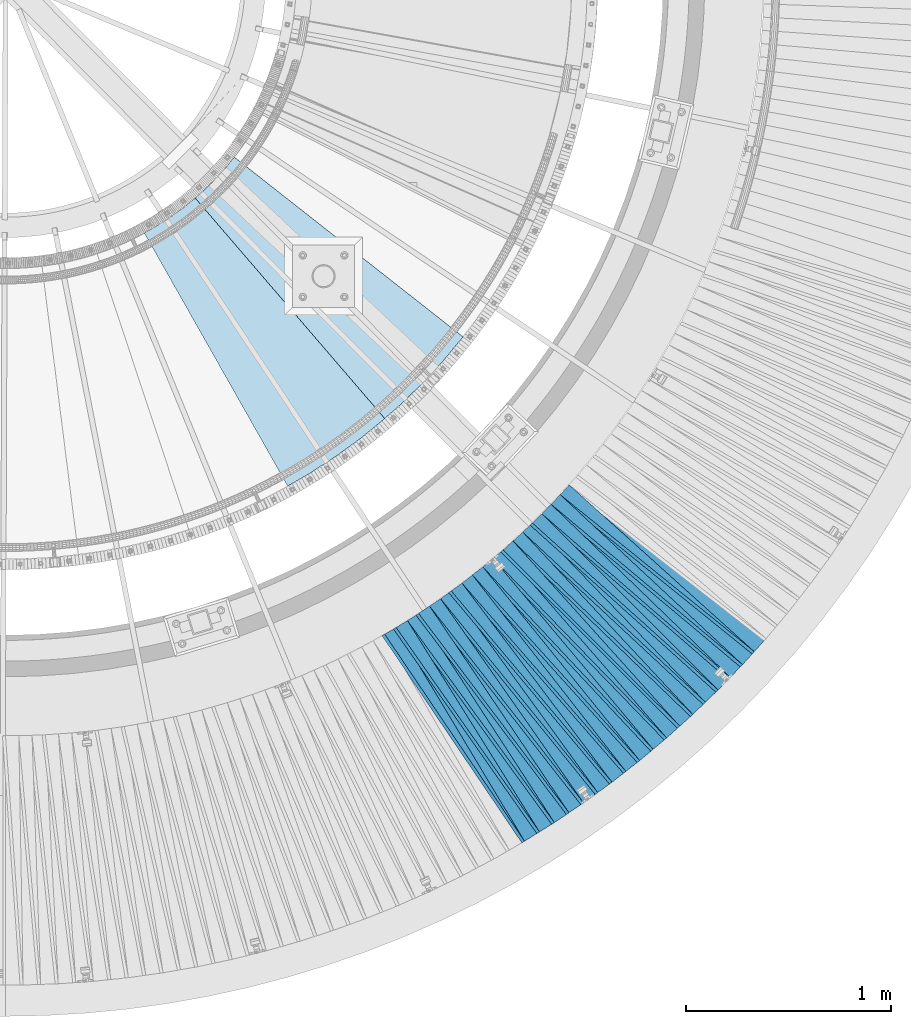
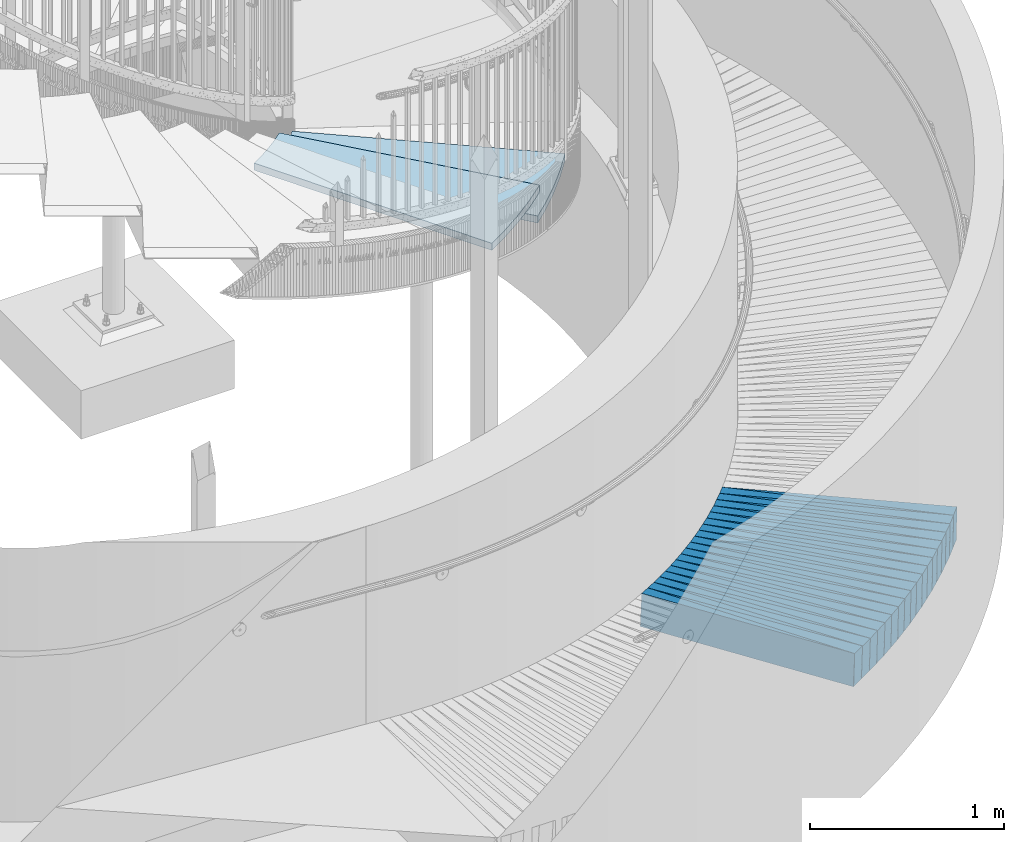
# One storey, part 832 of 975: 38 plates.
"""IFC2X3 building model written with IfcOpenShell, lengths in millimetres."""

from ifc_helpers import new_model, si_unit, frame, origin_with_axes, place, context, subcontext, project, spatial, faceted_brep, material, type_object, element, save


model = new_model("IFC2X3")

# Units and contexts
model_context = context("Model", 3, precision=1e-05, world=origin_with_axes())
body_context = subcontext(model_context, "Body", "Model", "MODEL_VIEW")
ifc_project = project(units=[si_unit("LENGTHUNIT", "METRE", prefix="MILLI"), si_unit("AREAUNIT", "SQUARE_METRE"), si_unit("VOLUMEUNIT", "CUBIC_METRE"), si_unit("MASSUNIT", "GRAM", prefix="KILO"), si_unit("TIMEUNIT", "SECOND"), si_unit("PLANEANGLEUNIT", "RADIAN"), si_unit("SOLIDANGLEUNIT", "STERADIAN"), si_unit("THERMODYNAMICTEMPERATUREUNIT", "DEGREE_CELSIUS"), si_unit("LUMINOUSINTENSITYUNIT", "LUMEN")], contexts=[model_context])

# Site, building, storey
site_placement = place(None, origin_with_axes())
site = spatial("IfcSite", under=ifc_project, at=site_placement, CompositionType="ELEMENT")
building_placement = place(site_placement, origin_with_axes())
building = spatial("IfcBuilding", under=site, at=building_placement, Name="Undefined", CompositionType="ELEMENT")
storey_placement = place(building_placement, origin_with_axes())
storey = spatial("IfcBuildingStorey", under=building, at=storey_placement, Name="Undefined", CompositionType="ELEMENT", Elevation=0.0)

# Plates
ifc_material_1 = material(Name="STEEL/A36")
plate_type_1 = type_object("IfcPlateType", PredefinedType="NOTDEFINED")
plate_1_placement = place(storey_placement, frame((37340.4592339061, -777.500208121454, 627.062023763603), z_axis=(-0.817299788050078, -0.573410252178987, 0.056760366007701), x_axis=(-0.57414473231509, 0.818743986449328, 0.00401385200220284)))
element("IfcPlate", 1, at=plate_1_placement, inside=storey, type_object=plate_type_1, material=ifc_material_1, Name="SLAB", context=body_context, shape_type="Brep", body=[
    faceted_brep([(-6.82121026329696e-12, -100.000000000011, -1.09139364212751e-10), (4.54009294510615, -99.9999999999918, 86.0067901611546), (4.54009294474236, 99.9999999999677, 86.0067901606271), (5.91171556152403e-12, 100.000000000011, 1.09139364212751e-10), (1220.77233886818, -99.9999999999491, -4.98403096571565e-10), (1220.77233886782, 100.00000000001, -1.02227204479277e-09)], [[[0, 1, 2, 3]], [[1, 4, 5, 2]], [[4, 0, 3, 5]], [[5, 3, 2]], [[4, 1, 0]]]),
])
plate_2_placement = place(storey_placement, frame((37413.3106687025, -732.147513354668, 622.068841281269), z_axis=(-0.807184923926217, -0.587448092964748, 0.0579416659952725), x_axis=(-0.588239751870621, 0.80867623682214, 0.00409124899910022)))
element("IfcPlate", 2, at=plate_2_placement, inside=storey, type_object=plate_type_1, material=ifc_material_1, Name="SLAB", context=body_context, shape_type="Brep", body=[
    faceted_brep([(-6.82121026329696e-12, -100.000000000011, -1.09139364212751e-10), (6.10836553567424, -100.000000000002, 85.8623809813835), (6.10836553595072, 100.00000000002, 85.8623809817509), (5.91171556152403e-12, 100.000000000011, 1.09139364212751e-10), (1222.12072754039, -99.9999999998786, 2.29920260608196e-09), (1222.12072754066, 100.000000000143, 2.66663846559823e-09)], [[[0, 1, 2, 3]], [[1, 4, 5, 2]], [[4, 0, 3, 5]], [[5, 3, 2]], [[4, 1, 0]]]),
])
plate_3_placement = place(storey_placement, frame((37484.7655241083, -684.067685249771, 617.161944634053), z_axis=(-0.796803579112582, -0.601567867133516, 0.0567464320095237), x_axis=(-0.602351830177366, 0.798220621235036, 0.00401404000118194)))
element("IfcPlate", 3, at=plate_3_placement, inside=storey, type_object=plate_type_1, material=ifc_material_1, Name="SLAB", context=body_context, shape_type="Brep", body=[
    faceted_brep([(-6.82121026329696e-12, -100.000000000011, -1.09139364212751e-10), (4.57294225681835, -100.000000000011, 86.0255661009323), (4.57294225706937, 100.000000000018, 86.0255661012743), (5.91171556152403e-12, 100.000000000011, 1.09139364212751e-10), (1220.71508789306, -99.9999999997754, 3.68527253158391e-09), (1220.71508789331, 100.000000000254, 4.02724253945053e-09)], [[[0, 1, 2, 3]], [[1, 4, 5, 2]], [[4, 0, 3, 5]], [[5, 3, 2]], [[4, 1, 0]]]),
])
plate_4_placement = place(storey_placement, frame((37556.0252663577, -636.114886571845, 612.168553459172), z_axis=(-0.78614168604072, -0.615328986134024, 0.0578920399738097), x_axis=(-0.6161707098645, 0.787602003826803, 0.0040914389991003)))
element("IfcPlate", 4, at=plate_4_placement, inside=storey, type_object=plate_type_1, material=ifc_material_1, Name="SLAB", context=body_context, shape_type="Brep", body=[
    faceted_brep([(-6.82121026329696e-12, -100.000000000011, -1.09139364212751e-10), (6.06977224327784, -100.000000000015, 85.9386901852631), (6.06977224361617, 100.000000000008, 85.9386901857069), (5.91171556152403e-12, 100.000000000011, 1.09139364212751e-10), (1222.06396484426, -99.9999999999895, -1.23691279441118e-09), (1222.0639648446, 100.000000000034, -7.96717358753085e-10)], [[[0, 1, 2, 3]], [[1, 4, 5, 2]], [[4, 0, 3, 5]], [[5, 3, 2]], [[4, 1, 0]]]),
])
plate_5_placement = place(storey_placement, frame((37625.6841162659, -585.597140831808, 607.168442500744), z_axis=(-0.775236426847244, -0.629014504488151, 0.0578725810089996), x_axis=(-0.629880829859821, 0.776680991827151, 0.00409598699908845)))
element("IfcPlate", 5, at=plate_5_placement, inside=storey, type_object=plate_type_1, material=ifc_material_1, Name="SLAB", context=body_context, shape_type="Brep", body=[
    faceted_brep([(-6.82121026329696e-12, -100.000000000011, -1.09139364212751e-10), (4.56012725799519, -100.000000000017, 86.0739517208203), (4.56012725838445, 100.00000000001, 86.0739517213005), (5.91171556152403e-12, 100.000000000011, 1.09139364212751e-10), (1220.70715332002, -100.000000000052, -1.87719706445932e-09), (1220.70715332041, 99.999999999975, -1.38970790430903e-09)], [[[0, 1, 2, 3]], [[1, 4, 5, 2]], [[4, 0, 3, 5]], [[5, 3, 2]], [[4, 1, 0]]]),
])
plate_6_placement = place(storey_placement, frame((37695.4344143507, -535.11381683741, 602.261958150688), z_axis=(-0.764205394462062, -0.642471518171804, 0.0567491269809581), x_axis=(-0.643328914129797, 0.765579409154459, 0.00400955400080898)))
element("IfcPlate", 6, at=plate_6_placement, inside=storey, type_object=plate_type_1, material=ifc_material_1, Name="SLAB", context=body_context, shape_type="Brep", body=[
    faceted_brep([(-6.82121026329696e-12, -100.000000000011, -1.09139364212751e-10), (6.13357925438322, -99.9999999999836, 85.9115753176593), (6.13357925428136, 100.000000000001, 85.9115753175283), (5.91171556152403e-12, 100.000000000011, 1.09139364212751e-10), (1222.08093261569, -100.000000000151, 9.24046617001295e-10), (1222.08093261558, 99.9999999998336, 7.93079379945993e-10)], [[[0, 1, 2, 3]], [[1, 4, 5, 2]], [[4, 0, 3, 5]], [[5, 3, 2]], [[4, 1, 0]]]),
])
plate_7_placement = place(storey_placement, frame((37763.2960629128, -482.191244136565, 597.361759114056), z_axis=(-0.752839887739705, -0.655755784483035, 0.0567137950159225), x_axis=(-0.656635700968691, 0.754197218964039, 0.00401386599980863)))
element("IfcPlate", 7, at=plate_7_placement, inside=storey, type_object=plate_type_1, material=ifc_material_1, Name="SLAB", context=body_context, shape_type="Brep", body=[
    faceted_brep([(-6.82121026329696e-12, -100.000000000011, -1.09139364212751e-10), (4.56711578393515, -99.9999999999745, 86.0755004885687), (4.56711578348404, 99.9999999999877, 86.0755004880448), (5.91171556152403e-12, 100.000000000011, 1.09139364212751e-10), (1220.76818847395, -100.000000000181, -2.5465851649642e-09), (1220.7681884735, 99.9999999997822, -3.07045411318541e-09)], [[[0, 1, 2, 3]], [[1, 4, 5, 2]], [[4, 0, 3, 5]], [[5, 3, 2]], [[4, 1, 0]]]),
])
plate_8_placement = place(storey_placement, frame((37830.958870795, -429.446752809858, 592.368908767477), z_axis=(-0.741292725861326, -0.668675192338485, 0.0579532720057703), x_axis=(-0.669618937953453, 0.74269356894837, 0.00409152499971561)))
element("IfcPlate", 8, at=plate_8_placement, inside=storey, type_object=plate_type_1, material=ifc_material_1, Name="SLAB", context=body_context, shape_type="Brep", body=[
    faceted_brep([(-6.82121026329696e-12, -100.000000000011, -1.09139364212751e-10), (6.06516981123787, -99.9999999999964, 85.8481979369899), (6.06516981141249, 100.000000000007, 85.8481979371863), (5.91171556152403e-12, 100.000000000011, 1.09139364212751e-10), (1222.03833007592, -100.000000000121, 1.78260961547494e-10), (1222.0383300761, 99.9999999998827, 3.74711817130446e-10)], [[[0, 1, 2, 3]], [[1, 4, 5, 2]], [[4, 0, 3, 5]], [[5, 3, 2]], [[4, 1, 0]]]),
])
plate_9_placement = place(storey_placement, frame((37896.9268117637, -374.221499889826, 587.368522940947), z_axis=(-0.729471737694206, -0.68155714405578, 0.0578864689882266), x_axis=(-0.682522639232813, 0.730852975249296, 0.00409579100139705)))
element("IfcPlate", 9, at=plate_9_placement, inside=storey, type_object=plate_type_1, material=ifc_material_1, Name="SLAB", context=body_context, shape_type="Brep", body=[
    faceted_brep([(-6.82121026329696e-12, -100.000000000011, -1.09139364212751e-10), (4.58255147939053, -99.9999999999968, 86.0517272949728), (4.58255147920863, 99.9999999999832, 86.0517272947764), (5.91171556152403e-12, 100.000000000011, 1.09139364212751e-10), (1220.76538085885, -100.00000000006, 2.07364792004228e-09), (1220.76538085867, 99.9999999999204, 1.87719706445932e-09)], [[[0, 1, 2, 3]], [[1, 4, 5, 2]], [[4, 0, 3, 5]], [[5, 3, 2]], [[4, 1, 0]]]),
])
plate_10_placement = place(storey_placement, frame((37962.891956133, -318.999135880989, 582.368471677323), z_axis=(-0.717502803833282, -0.69414686568028, 0.0578779349806324), x_axis=(-0.695136122552353, 0.718866490537068, 0.00409144299736518)))
element("IfcPlate", 10, at=plate_10_placement, inside=storey, type_object=plate_type_1, material=ifc_material_1, Name="SLAB", context=body_context, shape_type="Brep", body=[
    faceted_brep([(-6.82121026329696e-12, -100.000000000011, -1.09139364212751e-10), (6.07661056505822, -100.000000000004, 85.9591445921542), (6.07661056524375, 99.9999999999995, 85.9591445923361), (5.91171556152403e-12, 100.000000000011, 1.09139364212751e-10), (1222.06286620976, -100.000000000089, -2.08456185646355e-09), (1222.06286620995, 99.9999999999141, -1.90266291610897e-09)], [[[0, 1, 2, 3]], [[1, 4, 5, 2]], [[4, 0, 3, 5]], [[5, 3, 2]], [[4, 1, 0]]]),
])
plate_11_placement = place(storey_placement, frame((38026.9411273979, -261.50372590971, 577.462113578714), z_axis=(-0.70531401464431, -0.706617724536079, 0.0567761580047478), x_axis=(-0.707592411622809, 0.706609416623331, 0.00401389499786029)))
element("IfcPlate", 11, at=plate_11_placement, inside=storey, type_object=plate_type_1, material=ifc_material_1, Name="SLAB", context=body_context, shape_type="Brep", body=[
    faceted_brep([(-6.82121026329696e-12, -100.000000000011, -1.09139364212751e-10), (4.60478162772779, -99.9999999999982, 85.9782867432368), (4.6047816277096, 100.000000000011, 85.978286743215), (5.91171556152403e-12, 100.000000000011, 1.09139364212751e-10), (1220.75927734271, -100.000000000131, -4.54747350886464e-10), (1220.75927734269, 99.9999999998781, -4.83851181343198e-10)], [[[0, 1, 2, 3]], [[1, 4, 5, 2]], [[4, 0, 3, 5]], [[5, 3, 2]], [[4, 1, 0]]]),
])
plate_12_placement = place(storey_placement, frame((38090.8247872958, -204.051893272397, 572.46847013675), z_axis=(-0.692849881120439, -0.718755326034916, 0.0578776600065596), x_axis=(-0.719791537871013, 0.694178219875601, 0.00409158399926673)))
element("IfcPlate", 12, at=plate_12_placement, inside=storey, type_object=plate_type_1, material=ifc_material_1, Name="SLAB", context=body_context, shape_type="Brep", body=[
    faceted_brep([(-6.82121026329696e-12, -100.000000000011, -1.09139364212751e-10), (6.03047180157591, -100.000000000002, 85.962799072091), (6.03047180158683, 99.9999999999905, 85.9627990721056), (5.91171556152403e-12, 100.000000000011, 1.09139364212751e-10), (1222.02050781253, -100.000000000031, -2.87400325760245e-09), (1222.02050781254, 99.9999999999623, -2.85945134237409e-09)], [[[0, 1, 2, 3]], [[1, 4, 5, 2]], [[4, 0, 3, 5]], [[5, 3, 2]], [[4, 1, 0]]]),
])
plate_13_placement = place(storey_placement, frame((38152.6876074215, -144.431987099586, 567.468923656775), z_axis=(-0.680190066632634, -0.730741152133002, 0.0579555159896435), x_axis=(-0.731803298897877, 0.681503597904898, 0.00409606699942836)))
element("IfcPlate", 13, at=plate_13_placement, inside=storey, type_object=plate_type_1, material=ifc_material_1, Name="SLAB", context=body_context, shape_type="Brep", body=[
    faceted_brep([(-6.82121026329696e-12, -100.000000000011, -1.09139364212751e-10), (4.56015920626305, -100.000000000011, 85.9507675169698), (4.56015920648861, 100.000000000009, 85.9507675171772), (5.91171556152403e-12, 100.000000000011, 1.09139364212751e-10), (1220.68322753973, -99.9999999999422, 8.73114913702011e-10), (1220.68322753995, 100.000000000078, 1.08047970570624e-09)], [[[0, 1, 2, 3]], [[1, 4, 5, 2]], [[4, 0, 3, 5]], [[5, 3, 2]], [[4, 1, 0]]]),
])
plate_14_placement = place(storey_placement, frame((38214.7445650745, -84.7209643152564, 562.561929945479), z_axis=(-0.66742871232525, -0.742508596869494, 0.0567441410081655), x_axis=(-0.743548537900582, 0.668669942910596, 0.00400989199946383)))
element("IfcPlate", 14, at=plate_14_placement, inside=storey, type_object=plate_type_1, material=ifc_material_1, Name="SLAB", context=body_context, shape_type="Brep", body=[
    faceted_brep([(-6.82121026329696e-12, -100.000000000011, -1.09139364212751e-10), (6.125707149542, -99.9999999999914, 85.9196472168369), (6.12570714935282, 99.9999999999891, 85.9196472166659), (5.91171556152403e-12, 100.000000000011, 1.09139364212751e-10), (1221.97802734589, -99.9999999998367, 1.02954800240695e-09), (1221.9780273457, 100.000000000143, 8.62200977280736e-10)], [[[0, 1, 2, 3]], [[1, 4, 5, 2]], [[4, 0, 3, 5]], [[5, 3, 2]], [[4, 1, 0]]]),
])
plate_15_placement = place(storey_placement, frame((38274.5135351811, -22.892471689614, 557.661982756886), z_axis=(-0.654312991644378, -0.754091235254424, 0.0567531309959221), x_axis=(-0.755152960183586, 0.655536340159368, 0.00401415700097586)))
element("IfcPlate", 15, at=plate_15_placement, inside=storey, type_object=plate_type_1, material=ifc_material_1, Name="SLAB", context=body_context, shape_type="Brep", body=[
    faceted_brep([(-6.82121026329696e-12, -100.000000000011, -1.09139364212751e-10), (4.52460145969962, -99.9999999999877, 86.0188217164832), (4.52460145955774, 99.9999999999955, 86.0188217163595), (5.91171556152403e-12, 100.000000000011, 1.09139364212751e-10), (1220.67980957095, -99.9999999999154, 3.88172338716686e-09), (1220.67980957081, 100.000000000068, 3.75803210772574e-09)], [[[0, 1, 2, 3]], [[1, 4, 5, 2]], [[4, 0, 3, 5]], [[5, 3, 2]], [[4, 1, 0]]]),
])
plate_16_placement = place(storey_placement, frame((38334.3081481635, 38.8584544600747, 552.668318561874), z_axis=(-0.640961516440724, -0.765389794309958, 0.0578515099903855), x_axis=(-0.766515154065242, 0.64221318705466, 0.00409157200034823)))
element("IfcPlate", 16, at=plate_16_placement, inside=storey, type_object=plate_type_1, material=ifc_material_1, Name="SLAB", context=body_context, shape_type="Brep", body=[
    faceted_brep([(-6.82121026329696e-12, -100.000000000011, -1.09139364212751e-10), (6.10506772975714, -100.000000000008, 85.9963836668285), (6.10506772971348, 99.9999999999779, 85.9963836667921), (5.91171556152403e-12, 100.000000000011, 1.09139364212751e-10), (1222.02416992083, -100.000000000032, -3.93629306927323e-09), (1222.02416992079, 99.9999999999545, -3.97267285734415e-09)], [[[0, 1, 2, 3]], [[1, 4, 5, 2]], [[4, 0, 3, 5]], [[5, 3, 2]], [[4, 1, 0]]]),
])
plate_17_placement = place(storey_placement, frame((38391.8761431808, 102.682890299195, 547.668784509388), z_axis=(-0.627512222887243, -0.776448547276488, 0.0579315420072912), x_axis=(-0.777598789765197, 0.628747440810144, 0.00409607499876316)))
element("IfcPlate", 17, at=plate_17_placement, inside=storey, type_object=plate_type_1, material=ifc_material_1, Name="SLAB", context=body_context, shape_type="Brep", body=[
    faceted_brep([(-6.82121026329696e-12, -100.000000000011, -1.09139364212751e-10), (4.55544948573151, -100.000000000005, 85.9866714477212), (4.55544948627357, 100.00000000003, 85.9866714481577), (5.91171556152403e-12, 100.000000000011, 1.09139364212751e-10), (1220.68090819994, -100.000000000157, 5.0931703299284e-11), (1220.68090820048, 99.9999999998777, 4.83851181343198e-10)], [[[0, 1, 2, 3]], [[1, 4, 5, 2]], [[4, 0, 3, 5]], [[5, 3, 2]], [[4, 1, 0]]]),
])
plate_18_placement = place(storey_placement, frame((38449.5543763329, 166.518543594376, 542.668470148763), z_axis=(-0.613900427924084, -0.787258813876803, 0.0578776689917265), x_axis=(-0.788428239169034, 0.615113137131877, 0.00409148000087722)))
element("IfcPlate", 18, at=plate_18_placement, inside=storey, type_object=plate_type_1, material=ifc_material_1, Name="SLAB", context=body_context, shape_type="Brep", body=[
    faceted_brep([(-6.82121026329696e-12, -100.000000000011, -1.09139364212751e-10), (6.12819433195546, -100.000000000004, 85.9558944700875), (6.12819433236291, 100.000000000005, 85.9558944704077), (5.91171556152403e-12, 100.000000000011, 1.09139364212751e-10), (1222.05163574084, -100.000000000031, 3.67435859516263e-10), (1222.05163574125, 99.9999999999784, 6.91215973347425e-10)], [[[0, 1, 2, 3]], [[1, 4, 5, 2]], [[4, 0, 3, 5]], [[5, 3, 2]], [[4, 1, 0]]]),
])
plate_type_2 = type_object("IfcPlateType", PredefinedType="NOTDEFINED")
plate_19_placement = place(storey_placement, frame((37265.8310909285, -824.138648261918, 632.09738170496), z_axis=(-0.854603596577874, -0.513530819070835, 0.0770635489748533), x_axis=(-0.515062520794669, 0.857152611658298, 0.0)))
element("IfcPlate", 19, at=plate_19_placement, inside=storey, type_object=plate_type_2, material=ifc_material_1, Name="SLAB", context=body_context, shape_type="Brep", body=[
    faceted_brep([(-6.82121026329696e-12, -100.000000000011, -1.09139364212751e-10), (1220.34118652486, -99.9999999998145, 64.8815155052762), (1220.34118652502, 100.000000000199, 64.8815155055272), (5.91171556152403e-12, 100.000000000011, 1.09139364212751e-10), (1219.26940918113, -99.9999999998149, 4.49654180556536e-09), (1219.26940918128, 100.000000000199, 4.74756234325469e-09)], [[[0, 1, 2, 3]], [[1, 4, 5, 2]], [[4, 0, 3, 5]], [[5, 3, 2]], [[4, 1, 0]]]),
])
plate_20_placement = place(storey_placement, frame((37338.935711983, -778.569182963264, 627.185256102332), z_axis=(-0.845625287496813, -0.528413557934993, 0.0754783739650916), x_axis=(-0.529925201909685, 0.848044385855469, 0.0)))
element("IfcPlate", 20, at=plate_20_placement, inside=storey, type_object=plate_type_2, material=ifc_material_1, Name="SLAB", context=body_context, shape_type="Brep", body=[
    faceted_brep([(-6.82121026329696e-12, -100.000000000011, -1.09139364212751e-10), (1219.04492187548, -99.9999999999422, 64.9192581184361), (1219.0449218754, 100.000000000046, 64.9192581183052), (5.91171556152403e-12, 100.000000000011, 1.09139364212751e-10), (1219.03991699267, -99.9999999999413, -3.20142135024071e-10), (1219.03991699259, 100.000000000047, -4.51109372079372e-10)], [[[0, 1, 2, 3]], [[1, 4, 5, 2]], [[4, 0, 3, 5]], [[5, 3, 2]], [[4, 1, 0]]]),
])
plate_21_placement = place(storey_placement, frame((37411.7715881665, -733.267708198522, 622.197554654802), z_axis=(-0.83618226046679, -0.54300735543521, 0.0770859210485939), x_axis=(-0.544627921167396, 0.838677785257772, 0.0)))
element("IfcPlate", 21, at=plate_21_placement, inside=storey, type_object=plate_type_2, material=ifc_material_1, Name="SLAB", context=body_context, shape_type="Brep", body=[
    faceted_brep([(-6.82121026329696e-12, -100.000000000011, -1.09139364212751e-10), (1220.39831543037, -99.9999999999227, 64.8626861582125), (1220.39831543004, 100.000000000035, 64.8626861576849), (5.91171556152403e-12, 100.000000000011, 1.09139364212751e-10), (1219.18103027422, -99.9999999999109, 3.14321368932724e-09), (1219.1810302739, 100.000000000047, 2.62662069872022e-09)], [[[0, 1, 2, 3]], [[1, 4, 5, 2]], [[4, 0, 3, 5]], [[5, 3, 2]], [[4, 1, 0]]]),
])
plate_22_placement = place(storey_placement, frame((37483.2740136354, -685.193828763177, 617.285738250839), z_axis=(-0.826652884638133, -0.557618514670923, 0.0755420440261366), x_axis=(-0.559216409868327, 0.829021716804801, 0.0)))
element("IfcPlate", 22, at=plate_22_placement, inside=storey, type_object=plate_type_2, material=ifc_material_1, Name="SLAB", context=body_context, shape_type="Brep", body=[
    faceted_brep([(-6.82121026329696e-12, -100.000000000011, -1.09139364212751e-10), (1218.99060058753, -99.9999999998349, 64.8645401023714), (1218.99060058754, 100.000000000172, 64.8645401023787), (5.91171556152403e-12, 100.000000000011, 1.09139364212751e-10), (1219.02722168136, -99.999999999824, 9.45874489843845e-10), (1219.02722168136, 100.000000000183, 9.56788426265121e-10)], [[[0, 1, 2, 3]], [[1, 4, 5, 2]], [[4, 0, 3, 5]], [[5, 3, 2]], [[4, 1, 0]]]),
])
plate_23_placement = place(storey_placement, frame((37554.5300850216, -637.285289472499, 612.296802619493), z_axis=(-0.816719729973577, -0.571875545351961, 0.0769885920139173), x_axis=(-0.573577939727772, 0.81915099161122, 0.0)))
element("IfcPlate", 23, at=plate_23_placement, inside=storey, type_object=plate_type_2, material=ifc_material_1, Name="SLAB", context=body_context, shape_type="Brep", body=[
    faceted_brep([(-6.82121026329696e-12, -100.000000000011, -1.09139364212751e-10), (1220.3370361337, -99.9999999998931, 64.9446868909508), (1220.33703613408, 100.000000000141, 64.9446868915074), (5.91171556152403e-12, 100.000000000011, 1.09139364212751e-10), (1219.18920898512, -99.9999999999104, -1.30967237055302e-09), (1219.18920898551, 100.000000000124, -7.49423634260893e-10)], [[[0, 1, 2, 3]], [[1, 4, 5, 2]], [[4, 0, 3, 5]], [[5, 3, 2]], [[4, 1, 0]]]),
])
plate_24_placement = place(storey_placement, frame((37624.1985673384, -586.802588728837, 607.297758662935), z_axis=(-0.806547236421568, -0.586118800369957, 0.0771123029977299), x_axis=(-0.587869231945727, 0.808955972925313, 0.0)))
element("IfcPlate", 24, at=plate_24_placement, inside=storey, type_object=plate_type_2, material=ifc_material_1, Name="SLAB", context=body_context, shape_type="Brep", body=[
    faceted_brep([(-6.82121026329696e-12, -100.000000000011, -1.09139364212751e-10), (1218.98376464847, -100.0, 64.8404998779333), (1218.98376464862, 100.000000000013, 64.8404998781371), (5.91171556152403e-12, 100.000000000011, 1.09139364212751e-10), (1218.9785156249, -100.000000000012, 1.12413545139134e-09), (1218.97851562505, 100.000000000001, 1.33150024339557e-09)], [[[0, 1, 2, 3]], [[1, 4, 5, 2]], [[4, 0, 3, 5]], [[5, 3, 2]], [[4, 1, 0]]]),
])
plate_25_placement = place(storey_placement, frame((37694.0128618829, -536.309014400562, 602.384874443361), z_axis=(-0.796335078055628, -0.600134209930485, 0.0754279360001959), x_axis=(-0.60184872313246, 0.798610114175764, 0.0)))
element("IfcPlate", 25, at=plate_25_placement, inside=storey, type_object=plate_type_2, material=ifc_material_1, Name="SLAB", context=body_context, shape_type="Brep", body=[
    faceted_brep([(-6.82121026329696e-12, -100.000000000011, -1.09139364212751e-10), (1220.35314941515, -99.9999999998872, 64.9626693740393), (1220.35314941522, 100.000000000118, 64.9626693741484), (5.91171556152403e-12, 100.000000000011, 1.09139364212751e-10), (1219.24328613391, -99.9999999998859, -6.62112142890692e-10), (1219.24328613398, 100.00000000012, -5.49334799870849e-10)], [[[0, 1, 2, 3]], [[1, 4, 5, 2]], [[4, 0, 3, 5]], [[5, 3, 2]], [[4, 1, 0]]]),
])
plate_26_placement = place(storey_placement, frame((37761.8855048519, -483.419994319392, 597.485626793735), z_axis=(-0.785690468064358, -0.613991946865955, 0.0755273299975893), x_axis=(-0.615750695826085, 0.787941038777454, 0.0)))
element("IfcPlate", 26, at=plate_26_placement, inside=storey, type_object=plate_type_2, material=ifc_material_1, Name="SLAB", context=body_context, shape_type="Brep", body=[
    faceted_brep([(-6.82121026329696e-12, -100.000000000011, -1.09139364212751e-10), (1219.04309082064, -99.999999999965, 64.8771743778998), (1219.0430908202, 99.9999999999895, 64.8771743773359), (5.91171556152403e-12, 100.000000000011, 1.09139364212751e-10), (1218.99987792993, -99.9999999999723, -5.0931703299284e-11), (1218.99987792949, 99.9999999999827, -6.11180439591408e-10)], [[[0, 1, 2, 3]], [[1, 4, 5, 2]], [[4, 0, 3, 5]], [[5, 3, 2]], [[4, 1, 0]]]),
])
plate_27_placement = place(storey_placement, frame((37829.5528671419, -430.715122803815, 592.496872200316), z_axis=(-0.774826981002466, -0.627466747163234, 0.0769976020080817), x_axis=(-0.629335068033061, 0.777134076040822, 0.0)))
element("IfcPlate", 27, at=plate_27_placement, inside=storey, type_object=plate_type_2, material=ifc_material_1, Name="SLAB", context=body_context, shape_type="Brep", body=[
    faceted_brep([(-6.82121026329696e-12, -100.000000000011, -1.09139364212751e-10), (1220.31176757995, -99.9999999998199, 64.9370880149872), (1220.31176757975, 100.000000000155, 64.9370880147435), (5.91171556152403e-12, 100.000000000011, 1.09139364212751e-10), (1219.22338867366, -99.999999999824, 4.28190105594695e-09), (1219.22338867346, 100.000000000151, 4.0381564758718e-09)], [[[0, 1, 2, 3]], [[1, 4, 5, 2]], [[4, 0, 3, 5]], [[5, 3, 2]], [[4, 1, 0]]]),
])
plate_28_placement = place(storey_placement, frame((37895.5376329657, -375.519533862803, 587.496950171803), z_axis=(-0.763750033307546, -0.640902255468863, 0.0770076980414749), x_axis=(-0.642811084107487, 0.766024745128091, 0.0)))
element("IfcPlate", 28, at=plate_28_placement, inside=storey, type_object=plate_type_2, material=ifc_material_1, Name="SLAB", context=body_context, shape_type="Brep", body=[
    faceted_brep([(-6.82121026329696e-12, -100.000000000011, -1.09139364212751e-10), (1219.03747558625, -99.999999999975, 64.9285736087404), (1219.0374755864, 100.00000000004, 64.928573608915), (5.91171556152403e-12, 100.000000000011, 1.09139364212751e-10), (1219.02062988339, -99.9999999998413, 1.29512045532465e-09), (1219.02062988328, 100.000000000125, 9.24046617001295e-10)], [[[0, 1, 2, 3]], [[1, 4, 5, 2]], [[4, 0, 3, 5]], [[5, 3, 2]], [[4, 1, 0]]]),
])
plate_29_placement = place(storey_placement, frame((37961.5240776435, -320.322591354815, 582.497043051073), z_axis=(-0.752439718279415, -0.654142517179957, 0.0770197219747277), x_axis=(-0.656091391068783, 0.754681447079117, 0.0)))
element("IfcPlate", 29, at=plate_29_placement, inside=storey, type_object=plate_type_2, material=ifc_material_1, Name="SLAB", context=body_context, shape_type="Brep", body=[
    faceted_brep([(-6.82121026329696e-12, -100.000000000011, -1.09139364212751e-10), (1220.33728027083, -100.000000000231, 64.9184341400723), (1220.33728027037, 99.9999999997317, 64.9184341395412), (5.91171556152403e-12, 100.000000000011, 1.09139364212751e-10), (1219.18994140627, -100.000000000053, -7.20319803804159e-10), (1219.18994140625, 99.9999999999468, -8.36735125631094e-10)], [[[0, 1, 2, 3]], [[1, 4, 5, 2]], [[4, 0, 3, 5]], [[5, 3, 2]], [[4, 1, 0]]]),
])
plate_30_placement = place(storey_placement, frame((38025.6262192782, -262.821163536268, 577.58539173209), z_axis=(-0.741014199278478, -0.667231793804106, 0.0754962900057441), x_axis=(-0.669141468232745, 0.743135045258482, 0.0)))
element("IfcPlate", 30, at=plate_30_placement, inside=storey, type_object=plate_type_2, material=ifc_material_1, Name="SLAB", context=body_context, shape_type="Brep", body=[
    faceted_brep([(-6.82121026329696e-12, -100.000000000011, -1.09139364212751e-10), (1219.03271484594, -99.9999999998154, 64.903854372511), (1219.03271484619, 100.000000000201, 64.9038543727947), (5.91171556152403e-12, 100.000000000011, 1.09139364212751e-10), (1219.02478027554, -99.9999999998236, 4.86033968627453e-09), (1219.02478027579, 100.000000000194, 5.14774001203477e-09)], [[[0, 1, 2, 3]], [[1, 4, 5, 2]], [[4, 0, 3, 5]], [[5, 3, 2]], [[4, 1, 0]]]),
])
plate_31_placement = place(storey_placement, frame((38089.5024948305, -205.423733534546, 572.59719851706), z_axis=(-0.729151758999999, -0.680001893106715, 0.0770398450056238), x_axis=(-0.682028872827699, 0.731325246815245, 0.0)))
element("IfcPlate", 31, at=plate_31_placement, inside=storey, type_object=plate_type_2, material=ifc_material_1, Name="SLAB", context=body_context, shape_type="Brep", body=[
    faceted_brep([(-6.82121026329696e-12, -100.000000000011, -1.09139364212751e-10), (1220.29577636637, -100.000000000065, 64.901481627563), (1220.2957763663, 99.9999999999272, 64.9014816274939), (5.91171556152403e-12, 100.000000000011, 1.09139364212751e-10), (1219.15661621019, -100.000000000059, -2.71393219009042e-09), (1219.15661621013, 99.9999999999332, -2.78305378742516e-09)], [[[0, 1, 2, 3]], [[1, 4, 5, 2]], [[4, 0, 3, 5]], [[5, 3, 2]], [[4, 1, 0]]]),
])
plate_32_placement = place(storey_placement, frame((38151.3950187569, -145.820748609812, 567.597172898121), z_axis=(-0.71720862361176, -0.692587296608248, 0.0770365289573946), x_axis=(-0.694651612939842, 0.719346325937706, 0.0)))
element("IfcPlate", 32, at=plate_32_placement, inside=storey, type_object=plate_type_2, material=ifc_material_1, Name="SLAB", context=body_context, shape_type="Brep", body=[
    faceted_brep([(-6.82121026329696e-12, -100.000000000011, -1.09139364212751e-10), (1218.95654296832, -100.000000000036, 64.9042739863908), (1218.95654296788, 99.9999999999391, 64.9042739859324), (5.91171556152403e-12, 100.000000000011, 1.09139364212751e-10), (1218.88439941372, -100.000000000031, -2.21916707232594e-09), (1218.88439941328, 99.9999999999445, -2.6775524020195e-09)], [[[0, 1, 2, 3]], [[1, 4, 5, 2]], [[4, 0, 3, 5]], [[5, 3, 2]], [[4, 1, 0]]]),
])
plate_33_placement = place(storey_placement, frame((38213.4967138194, -86.1092930426168, 562.685552952074), z_axis=(-0.705087616882403, -0.705087616882401, 0.075517580987405), x_axis=(-0.707106781186601, 0.707106781186494, 2.36468622460961e-14)))
element("IfcPlate", 33, at=plate_33_placement, inside=storey, type_object=plate_type_2, material=ifc_material_1, Name="SLAB", context=body_context, shape_type="Brep", body=[
    faceted_brep([(-6.82121026329696e-12, -100.000000000011, -1.09139364212751e-10), (1220.25415038898, -100.000000000122, 64.8855514509924), (1220.25415038909, 99.9999999998854, 64.8855514510942), (5.91171556152403e-12, 100.000000000011, 1.09139364212751e-10), (1219.1934814438, -100.000000000115, -3.23780113831162e-10), (1219.1934814439, 99.9999999998931, -2.18278728425503e-10)], [[[0, 1, 2, 3]], [[1, 4, 5, 2]], [[4, 0, 3, 5]], [[5, 3, 2]], [[4, 1, 0]]]),
])
plate_34_placement = place(storey_placement, frame((38273.2861753354, -24.307103559489, 557.786088162007), z_axis=(-0.692623419408702, -0.717327833233993, 0.0755882170342806), x_axis=(-0.71938591114976, 0.694610618144604, 0.0)))
element("IfcPlate", 34, at=plate_34_placement, inside=storey, type_object=plate_type_2, material=ifc_material_1, Name="SLAB", context=body_context, shape_type="Brep", body=[
    faceted_brep([(-6.82121026329696e-12, -100.000000000011, -1.09139364212751e-10), (1218.95739746141, -99.9999999999632, 64.8249206547589), (1218.9573974616, 100.000000000053, 64.8249206549372), (5.91171556152403e-12, 100.000000000011, 1.09139364212751e-10), (1218.95629882815, -99.9999999999354, 7.27595761418343e-10), (1218.95629882811, 100.000000000061, 5.5297277867794e-10)], [[[0, 1, 2, 3]], [[1, 4, 5, 2]], [[4, 0, 3, 5]], [[5, 3, 2]], [[4, 1, 0]]]),
])
plate_35_placement = place(storey_placement, frame((38333.0879522701, 37.4012691297898, 552.796629335879), z_axis=(-0.679921240452132, -0.729234748900048, 0.0769661469655157), x_axis=(-0.731404308627705, 0.681944086652879, 0.0)))
element("IfcPlate", 35, at=plate_35_placement, inside=storey, type_object=plate_type_2, material=ifc_material_1, Name="SLAB", context=body_context, shape_type="Brep", body=[
    faceted_brep([(-6.82121026329696e-12, -100.000000000011, -1.09139364212751e-10), (1220.29614258009, -99.9999999998645, 64.9636230487085), (1220.29614257993, 100.00000000013, 64.9636230485521), (5.91171556152403e-12, 100.000000000011, 1.09139364212751e-10), (1219.16149902545, -99.9999999998586, 3.56885720975697e-09), (1219.16149902527, 100.000000000136, 3.40878614224494e-09)], [[[0, 1, 2, 3]], [[1, 4, 5, 2]], [[4, 0, 3, 5]], [[5, 3, 2]], [[4, 1, 0]]]),
])
plate_36_placement = place(storey_placement, frame((38390.6827006264, 101.206072990672, 547.79710684265), z_axis=(-0.667108231473736, -0.74096781168234, 0.0770279790119732), x_axis=(-0.743175837929349, 0.669096161936392, 0.0)))
element("IfcPlate", 36, at=plate_36_placement, inside=storey, type_object=plate_type_2, material=ifc_material_1, Name="SLAB", context=body_context, shape_type="Brep", body=[
    faceted_brep([(-6.82121026329696e-12, -100.000000000011, -1.09139364212751e-10), (1218.95385742392, -99.9999999998627, 64.9114761370911), (1218.95385742374, 100.000000000134, 64.9114761369274), (5.91171556152403e-12, 100.000000000011, 1.09139364212751e-10), (1218.95776367403, -99.9999999998549, 1.18961906991899e-09), (1218.95776367385, 100.000000000141, 1.02591002359986e-09)], [[[0, 1, 2, 3]], [[1, 4, 5, 2]], [[4, 0, 3, 5]], [[5, 3, 2]], [[4, 1, 0]]]),
])
ifc_material_2 = material(Name="STEEL/Zero_Density")
plate_type_3 = type_object("IfcPlateType", PredefinedType="NOTDEFINED")
for number, where, z_axis, x_axis, name in (
    (37, (35853.1175912426, 2524.92227957338, 2466.975), (0.752279481038242, -0.65884412603349, 0.0), (-0.658844126033488, -0.752279481038244, 0.0), "CONC."),
    (38, (35661.8222053706, 2324.96503893202, 2644.775), (0.610480042976096, -0.79203163896899, 0.0), (-0.792031638968988, -0.610480042976098, 0.0), "CONC."),
):
    element("IfcPlate", number, at=place(storey_placement, frame(where, z_axis=z_axis, x_axis=x_axis)), inside=storey, type_object=plate_type_3, material=ifc_material_2, Name=name, context=body_context, shape_type="Brep", body=[
        faceted_brep([(226.607026755963, -22.2249999999999, -5.9806827134089), (151.21244687953, -22.2249999999999, 0.0171956564081484), (151.21244687953, 22.2249999999999, 0.0171956564081484), (226.607026755963, 22.2249999999999, -5.9806827134089), (75.6059955448145, -22.2249999999999, 2.01262449634305), (75.6059955448145, 22.2249999999999, 2.01262449634305), (0.0, -22.2249999999999, 0.0), (6.3512526843333, 22.2249999999999, 0.169069749597838), (-75.9923477177144, -22.2249999999999, 1420.59179687598), (-69.6411756631605, 22.2249999999999, 1420.76237488879), (75.2887648406067, -22.2249999999999, 1424.6548629265), (75.2887648406067, 22.2249999999999, 1424.6548629265), (226.570657118533, -22.2249999999999, 1420.62093290526), (226.570657118533, 22.2249999999999, 1420.62093290526), (377.420264969449, -22.2249999999999, 1408.50155446305), (377.420264969449, 22.2249999999999, 1408.50155446305), (501.974970329931, -22.2249999999999, 1391.75136796272), (501.974970329931, 22.2249999999999, 1391.75136796272), (301.578002929167, 22.2249999999999, -15.9641666403222), (301.578002929167, -22.2249999999999, -15.9641666403222)], [[[0, 1, 2, 3]], [[1, 4, 5, 2]], [[5, 4, 6, 7]], [[8, 9, 7, 6]], [[10, 11, 9, 8]], [[10, 12, 13, 11]], [[12, 14, 15, 13]], [[15, 14, 16, 17]], [[3, 2, 5, 7, 9, 11, 13, 15, 17, 18]], [[0, 3, 18, 19]], [[14, 12, 10, 8, 6, 4, 1, 0, 19, 16]], [[18, 17, 16, 19]]]),
    ])

save(model, "model.ifc")
